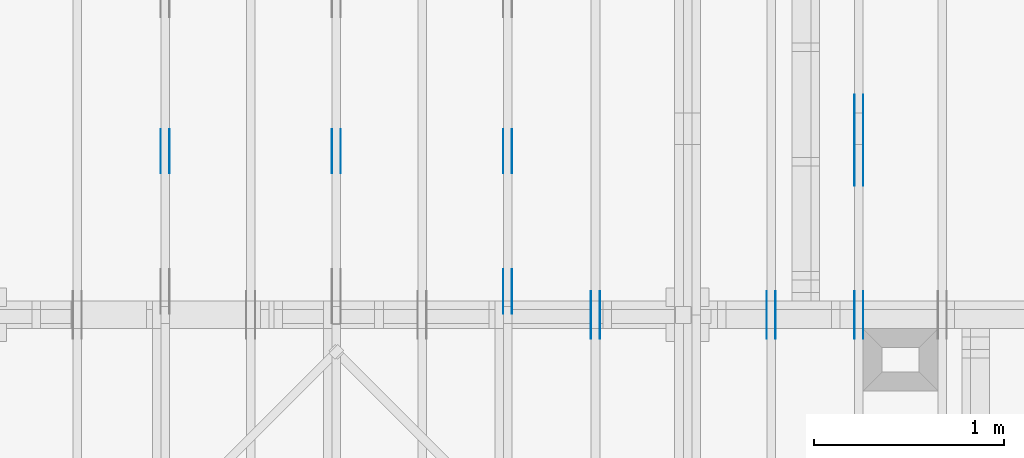
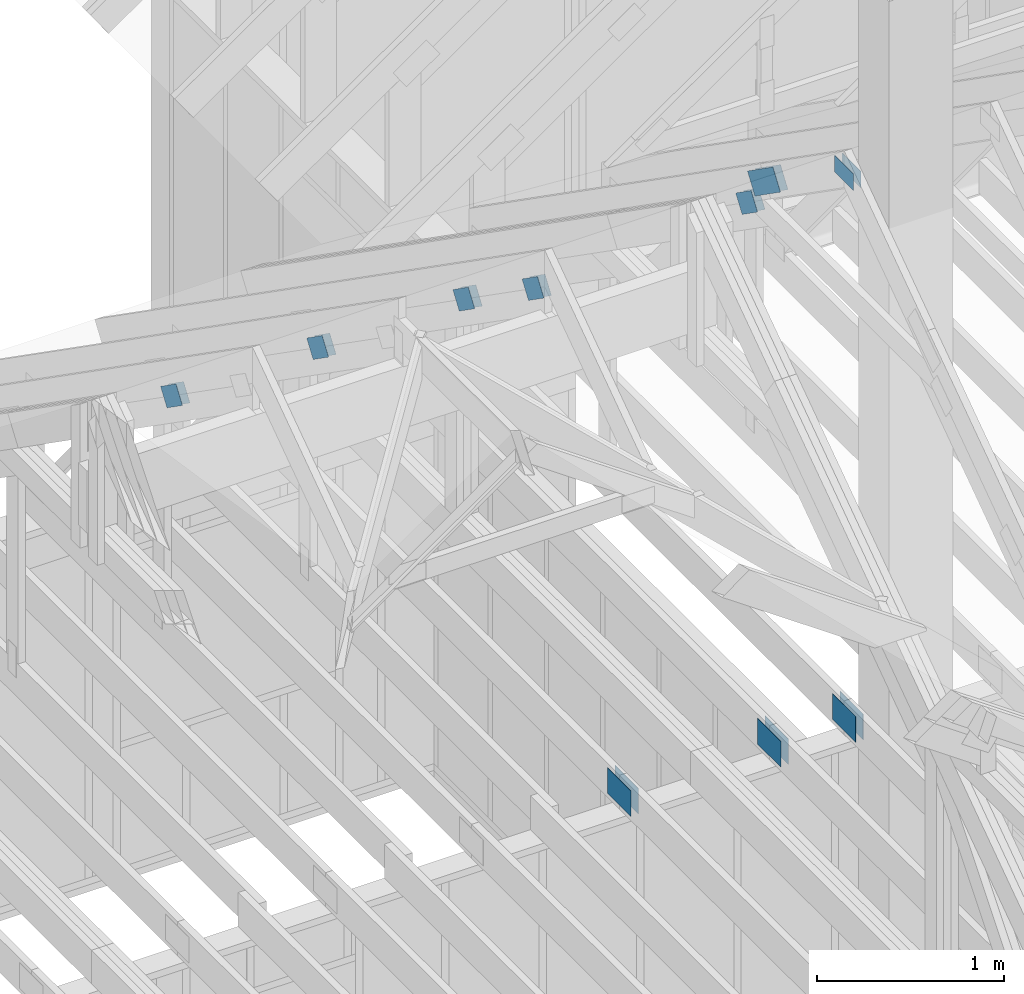
# One storey, part 49 of 70: 20 plates, 6 elements without a shape of their own.
"""IFC2X3 building model written with IfcOpenShell, lengths in millimetres."""

from ifc_helpers import new_model, si_unit, frame, origin, origin_with_axes, origin_2d, place, context, project, spatial, faceted_brep, element, aggregate, save


model = new_model("IFC2X3")

# Units and contexts
model_context = context("Model", 3, precision=1e-05, world=origin())
plan_context = context("Plan", 2, precision=1e-05, world=origin_2d())
ifc_project = project(units=[si_unit("LENGTHUNIT", "METRE", prefix="MILLI"), si_unit("AREAUNIT", "SQUARE_METRE"), si_unit("VOLUMEUNIT", "CUBIC_METRE"), si_unit("SOLIDANGLEUNIT", "STERADIAN"), si_unit("PLANEANGLEUNIT", "RADIAN"), si_unit("MASSUNIT", "GRAM"), si_unit("TIMEUNIT", "SECOND"), si_unit("THERMODYNAMICTEMPERATUREUNIT", "DEGREE_CELSIUS"), si_unit("LUMINOUSINTENSITYUNIT", "LUMEN")], contexts=[model_context, plan_context])

# Site, building, storey
site_placement = place(None, origin_with_axes())
site = spatial("IfcSite", under=ifc_project, at=site_placement, CompositionType="ELEMENT")
building_placement = place(site_placement, origin_with_axes())
building = spatial("IfcBuilding", under=site, at=building_placement, Name="Layout 1", CompositionType="ELEMENT")
storey_placement = place(building_placement, origin_with_axes())
storey = spatial("IfcBuildingStorey", under=building, at=storey_placement, Name="Storey 1", CompositionType="ELEMENT", Elevation=0.0)

# Assembly, plates
assembly_1_placement = place(storey_placement, frame((5266.250000000146, 8000.0, 1.3776821480501744e-15), z_axis=(-1.0, 1.836909530733566e-16, 6.123031769111886e-17), x_axis=(-1.836909530733566e-16, -1.0, 0.0)))
assembly_1 = element("IfcElementAssembly", 1, at=assembly_1_placement, inside=storey, Name="MB1", AssemblyPlace="FACTORY", PredefinedType="TRUSS")
plate_1_placement = place(assembly_1_placement, frame((4125.0, 193.99999999999994, 0.0), z_axis=(0.0, 0.0, 1.0), x_axis=(-1.0, 1.2246063538223773e-16, 0.0)))
plate_1 = element("IfcPlate", 2, at=plate_1_placement, context=model_context, shape_type="Brep", body=[
    faceted_brep([(250.0, 168.0, 1.3), (0.0, 168.0, 1.3), (0.0, 0.0, 1.3), (250.0, 0.0, 1.3), (0.0, 168.0, 0.0), (250.0, 168.0, 3.061515884555943e-14), (250.0, 0.0, 3.061515884555943e-14), (0.0, 0.0, 0.0), (250.0, -4.592273826833915e-14, 2.8118638534165077e-30), (250.0, -4.5843138855340694e-14, 1.3), (1.4621692037765842e-32, 7.959941299845453e-17, 1.3), (0.0, 0.0, 0.0), (250.0, 168.0, 0.0), (250.0, 168.0, 1.3), (250.0, 0.0, 1.3), (250.0, 0.0, 0.0), (0.0, 168.0, 0.0), (-4.8738973459219465e-33, 168.0, 1.3), (250.0, 167.99999999999997, 1.3), (250.0, 167.99999999999997, -1.5777218104420236e-30), (0.0, 0.0, 0.0), (7.959941299845453e-17, -9.747794691843893e-33, 1.3), (2.065298615721439e-14, 168.0, 1.3), (2.0573386744215938e-14, 168.0, -1.2597150063305954e-30)], [[[0, 1, 2, 3]], [[4, 5, 6, 7]], [[8, 9, 10, 11]], [[12, 13, 14, 15]], [[16, 17, 18, 19]], [[20, 21, 22, 23]]]),
])
plate_2_placement = place(assembly_1_placement, frame((4125.0, 193.99999999999994, -46.3), z_axis=(0.0, 0.0, 1.0), x_axis=(-1.0, 1.2246063538223773e-16, 0.0)))
plate_2 = element("IfcPlate", 3, at=plate_2_placement, context=model_context, shape_type="Brep", body=[
    faceted_brep([(250.0, 168.0, 1.2999999999999972), (0.0, 168.0, 1.2999999999999972), (0.0, 0.0, 1.2999999999999972), (250.0, 0.0, 1.2999999999999972), (0.0, 168.0, 0.0), (250.0, 168.0, 3.061515884555943e-14), (250.0, 0.0, 3.061515884555943e-14), (0.0, 0.0, 0.0), (250.0, -4.592273826833915e-14, 2.8118638534165077e-30), (250.0, -4.5843138855340694e-14, 1.2999999999999972), (1.462169203776581e-32, 7.959941299845434e-17, 1.2999999999999972), (0.0, 0.0, 0.0), (250.0, 168.0, 0.0), (250.0, 168.0, 1.2999999999999972), (250.0, 0.0, 1.2999999999999972), (250.0, 0.0, 0.0), (0.0, 168.0, 0.0), (-4.873897345921936e-33, 168.0, 1.2999999999999972), (250.0, 167.99999999999997, 1.2999999999999972), (250.0, 167.99999999999997, -1.5777218104420236e-30), (0.0, 0.0, 0.0), (7.959941299845434e-17, -9.747794691843873e-33, 1.2999999999999972), (2.065298615721439e-14, 168.0, 1.2999999999999972), (2.0573386744215938e-14, 168.0, -1.2597150063305954e-30)], [[[0, 1, 2, 3]], [[4, 5, 6, 7]], [[8, 9, 10, 11]], [[12, 13, 14, 15]], [[16, 17, 18, 19]], [[20, 21, 22, 23]]]),
])
aggregate(assembly_1, [plate_1, plate_2])

assembly_2_placement = place(storey_placement, frame((6188.750000000146, 8000.0, 1.3776821480501744e-15), z_axis=(-1.0, 1.836909530733566e-16, 6.123031769111886e-17), x_axis=(-1.836909530733566e-16, -1.0, 0.0)))
assembly_2 = element("IfcElementAssembly", 4, at=assembly_2_placement, inside=storey, Name="MB1", AssemblyPlace="FACTORY", PredefinedType="TRUSS")
plate_3_placement = place(assembly_2_placement, frame((4125.0, 193.99999999999994, 0.0), z_axis=(0.0, 0.0, 1.0), x_axis=(-1.0, 1.2246063538223773e-16, 0.0)))
plate_3 = element("IfcPlate", 5, at=plate_3_placement, context=model_context, shape_type="Brep", body=[
    faceted_brep([(250.0, 168.0, 1.3), (0.0, 168.0, 1.3), (0.0, 0.0, 1.3), (250.0, 0.0, 1.3), (0.0, 168.0, 0.0), (250.0, 168.0, 3.061515884555943e-14), (250.0, 0.0, 3.061515884555943e-14), (0.0, 0.0, 0.0), (250.0, -4.592273826833915e-14, 2.8118638534165077e-30), (250.0, -4.5843138855340694e-14, 1.3), (1.4621692037765842e-32, 7.959941299845453e-17, 1.3), (0.0, 0.0, 0.0), (250.0, 168.0, 0.0), (250.0, 168.0, 1.3), (250.0, 0.0, 1.3), (250.0, 0.0, 0.0), (0.0, 168.0, 0.0), (-4.8738973459219465e-33, 168.0, 1.3), (250.0, 167.99999999999997, 1.3), (250.0, 167.99999999999997, -1.5777218104420236e-30), (0.0, 0.0, 0.0), (7.959941299845453e-17, -9.747794691843893e-33, 1.3), (2.065298615721439e-14, 168.0, 1.3), (2.0573386744215938e-14, 168.0, -1.2597150063305954e-30)], [[[0, 1, 2, 3]], [[4, 5, 6, 7]], [[8, 9, 10, 11]], [[12, 13, 14, 15]], [[16, 17, 18, 19]], [[20, 21, 22, 23]]]),
])
plate_4_placement = place(assembly_2_placement, frame((4125.0, 193.99999999999994, -46.3), z_axis=(0.0, 0.0, 1.0), x_axis=(-1.0, 1.2246063538223773e-16, 0.0)))
plate_4 = element("IfcPlate", 6, at=plate_4_placement, context=model_context, shape_type="Brep", body=[
    faceted_brep([(250.0, 168.0, 1.2999999999999972), (0.0, 168.0, 1.2999999999999972), (0.0, 0.0, 1.2999999999999972), (250.0, 0.0, 1.2999999999999972), (0.0, 168.0, 0.0), (250.0, 168.0, 3.061515884555943e-14), (250.0, 0.0, 3.061515884555943e-14), (0.0, 0.0, 0.0), (250.0, -4.592273826833915e-14, 2.8118638534165077e-30), (250.0, -4.5843138855340694e-14, 1.2999999999999972), (1.462169203776581e-32, 7.959941299845434e-17, 1.2999999999999972), (0.0, 0.0, 0.0), (250.0, 168.0, 0.0), (250.0, 168.0, 1.2999999999999972), (250.0, 0.0, 1.2999999999999972), (250.0, 0.0, 0.0), (0.0, 168.0, 0.0), (-4.873897345921936e-33, 168.0, 1.2999999999999972), (250.0, 167.99999999999997, 1.2999999999999972), (250.0, 167.99999999999997, -1.5777218104420236e-30), (0.0, 0.0, 0.0), (7.959941299845434e-17, -9.747794691843873e-33, 1.2999999999999972), (2.065298615721439e-14, 168.0, 1.2999999999999972), (2.0573386744215938e-14, 168.0, -1.2597150063305954e-30)], [[[0, 1, 2, 3]], [[4, 5, 6, 7]], [[8, 9, 10, 11]], [[12, 13, 14, 15]], [[16, 17, 18, 19]], [[20, 21, 22, 23]]]),
])
aggregate(assembly_2, [plate_3, plate_4])

assembly_3_placement = place(storey_placement, frame((6650.000000000001, 8000.0, -9.081170196248781e-13), z_axis=(-1.0, 1.836909530733566e-16, 6.123031769111886e-17), x_axis=(-1.836909530733566e-16, -1.0, 0.0)))
assembly_3 = element("IfcElementAssembly", 7, at=assembly_3_placement, inside=storey, Name="T12", AssemblyPlace="FACTORY", PredefinedType="TRUSS")
plate_5_placement = place(assembly_3_placement, frame((3241.212504107585, 3235.9501271276167, 0.0), z_axis=(0.0, 0.0, 1.0), x_axis=(-0.8191520442889914, -0.5735764363510467, 0.0)))
plate_5 = element("IfcPlate", 8, at=plate_5_placement, context=model_context, shape_type="Brep", body=[
    faceted_brep([(330.0000000000009, 140.00000000000045, 1.5), (134.0000000000009, 140.00000000000045, 1.5), (134.0, 4.547473508864641e-13, 1.5), (330.0000000000009, 4.547473508864641e-13, 1.5), (133.9000001978775, 140.00000000000045, 1.5), (9.094947017729282e-13, 140.00000000000045, 1.5), (0.0, 4.547473508864641e-13, 1.5), (133.90000101970236, 4.547473508864641e-13, 1.5), (330.0000000000009, 140.00000000000045, 0.0), (134.0000000000009, 140.00000000000045, 0.0), (134.0, 4.547473508864641e-13, 0.0), (330.0000000000009, 4.547473508864641e-13, 0.0), (133.9000001978775, 140.00000000000045, 0.0), (9.094947017729282e-13, 140.00000000000045, 0.0), (0.0, 4.547473508864641e-13, 0.0), (133.90000101970236, 4.547473508864641e-13, 0.0), (330.0000000000009, 9.803270933743405e-13, -4.610357698653557e-29), (330.0000000000009, 9.804189388508772e-13, 1.5), (134.0, 6.682564251308046e-13, 1.5), (134.0, 6.681645796542679e-13, -4.091192948218372e-29), (133.90000101970236, 6.680053146896804e-13, 8.643095081543955e-31), (133.90000101970236, 6.680971601662171e-13, 1.5), (-1.4627915729340467e-31, 4.548391963630008e-13, 1.5), (0.0, 4.547473508864641e-13, 0.0), (133.90000101970236, 140.00000000000068, 5.032059779604519e-23), (133.90000101970236, 140.00000000000068, 1.5), (133.90000101970236, 6.821210263296962e-13, 1.5), (133.90000101970236, 6.821210263296962e-13, 0.0), (9.094947017729282e-13, 140.00000000000045, 0.0), (9.094947017729282e-13, 140.00000000000045, 1.5), (133.9000001978775, 140.00000000000068, 1.5), (133.9000001978775, 140.00000000000068, 1.5777218104420236e-30), (134.0000000000009, 140.00000000000068, 1.4199496293978212e-29), (134.0000000000009, 140.00000000000068, 1.5), (330.0000000000009, 140.00000000000102, 1.5), (330.0000000000009, 140.00000000000102, 2.208810534618833e-29), (5.56886495279458e-29, 4.547473508864641e-13, -3.409833702385498e-45), (9.184547653673398e-17, 4.547473508864641e-13, 1.5), (8.876511857361728e-13, 140.00000000000045, 1.5), (8.875593402596361e-13, 140.00000000000045, 1.3431091541284187e-30), (330.0000000000009, 140.00000000000068, 0.0), (330.0000000000009, 140.00000000000068, 1.5), (330.0000000000009, 2.2737367544323206e-13, 1.5), (330.0000000000009, 2.2737367544323206e-13, 0.0), (134.0, 0.0, 0.0), (134.0, 0.0, 1.5), (134.00000000000088, 140.00000000000045, 1.5), (134.00000000000088, 140.00000000000045, 1.5777218104420236e-30)], [[[0, 1, 2, 3]], [[4, 5, 6, 7]], [[8, 9, 10, 11]], [[12, 13, 14, 15]], [[16, 17, 18, 19]], [[20, 21, 22, 23]], [[24, 25, 26, 27]], [[28, 29, 30, 31]], [[32, 33, 34, 35]], [[36, 37, 38, 39]], [[40, 41, 42, 43]], [[44, 45, 46, 47]]]),
])
plate_6_placement = place(assembly_3_placement, frame((3241.212504107585, 3235.9501271276167, -46.5), z_axis=(0.0, 0.0, 1.0), x_axis=(-0.8191520442889914, -0.5735764363510467, 0.0)))
plate_6 = element("IfcPlate", 9, at=plate_6_placement, context=model_context, shape_type="Brep", body=[
    faceted_brep([(330.0000000000009, 140.00000000000045, 0.0), (134.0000000000009, 140.00000000000045, 0.0), (134.0, 4.547473508864641e-13, 0.0), (330.0000000000009, 4.547473508864641e-13, 0.0), (133.9000001978775, 140.00000000000045, 0.0), (9.094947017729282e-13, 140.00000000000045, 0.0), (0.0, 4.547473508864641e-13, 0.0), (133.90000101970236, 4.547473508864641e-13, 0.0), (330.0000000000009, 140.00000000000045, 1.5), (134.0000000000009, 140.00000000000045, 1.5), (134.0, 4.547473508864641e-13, 1.5), (330.0000000000009, 4.547473508864641e-13, 1.5), (133.9000001978775, 140.00000000000045, 1.5), (9.094947017729282e-13, 140.00000000000045, 1.5), (0.0, 4.547473508864641e-13, 1.5), (133.90000101970236, 4.547473508864641e-13, 1.5), (0.0, 4.547473508864641e-13, 0.0), (1.575266127070707e-31, 4.5465550540992744e-13, 1.5), (133.90000101970236, 6.843109484156988e-13, 1.5), (133.90000101970236, 6.844027938922355e-13, 1.397133527515671e-31), (134.0, 6.845743047954878e-13, 4.191670216580455e-29), (134.0, 6.844824593189511e-13, 1.5), (330.0000000000009, 1.0206472575739425e-12, 1.5), (330.0000000000009, 1.0207391030504792e-12, 4.85780171775421e-29), (133.90000101970236, 6.821210263296962e-13, 0.0), (133.90000101970236, 6.821210263296962e-13, 1.5), (133.90000019787752, 140.00000000000068, 1.5), (133.90000019787752, 140.00000000000068, 0.0), (330.0000000000009, 140.00000000000097, -1.8932661725304283e-29), (330.0000000000009, 140.00000000000097, 1.5), (134.00000000000094, 140.00000000000068, 1.5), (134.00000000000094, 140.00000000000068, -1.262177448353619e-29), (133.90000019787752, 140.00000000000068, 0.0), (133.90000019787752, 140.00000000000068, 1.5), (9.094947017729282e-13, 140.00000000000045, 1.5), (9.094947017729282e-13, 140.00000000000045, 0.0), (-2.8272774843121063e-27, 140.00000000000045, -5.568864952794597e-29), (-9.184547653950557e-17, 140.00000000000045, 1.5), (-9.184547653950557e-17, 4.547473508864641e-13, 1.5), (-2.8272774843121063e-27, 4.547473508864641e-13, -1.731150985653776e-43), (330.0000000000009, 2.2737367544323206e-13, 0.0), (330.0000000000009, 2.2737367544323206e-13, 1.5), (330.0000000000009, 140.00000000000068, 1.5), (330.0000000000009, 140.00000000000068, 0.0), (134.0, 140.00000000000045, -5.522026336547083e-29), (134.0, 140.00000000000045, 1.5), (134.0, 0.0, 1.5), (134.0, 0.0, 0.0)], [[[0, 1, 2, 3]], [[4, 5, 6, 7]], [[8, 9, 10, 11]], [[12, 13, 14, 15]], [[16, 17, 18, 19]], [[20, 21, 22, 23]], [[24, 25, 26, 27]], [[28, 29, 30, 31]], [[32, 33, 34, 35]], [[36, 37, 38, 39]], [[40, 41, 42, 43]], [[44, 45, 46, 47]]]),
])
plate_7_placement = place(assembly_3_placement, frame((3899.9999999999995, 3603.8046304341406, 0.0), z_axis=(0.0, 0.0, 1.0), x_axis=(1.0, 0.0, 0.0)))
plate_7 = element("IfcPlate", 10, at=plate_7_placement, context=model_context, shape_type="Brep", body=[
    faceted_brep([(200.00000000000045, 108.0, 1.3), (0.0, 108.0, 1.3), (0.0, 0.0, 1.3), (200.00000000000045, 0.0, 1.3), (0.0, 108.0, 0.0), (200.00000000000045, 108.0, 2.4492127076447602e-14), (200.00000000000045, 0.0, 2.4492127076447602e-14), (0.0, 0.0, 0.0), (200.00000000000045, -3.67381906146714e-14, 2.2494910827332114e-30), (200.00000000000045, -3.6658591201672947e-14, 1.3), (1.4621692037765842e-32, 7.959941299845453e-17, 1.3), (0.0, 0.0, 0.0), (200.00000000000045, 108.0, 0.0), (200.00000000000045, 108.0, 1.3), (200.00000000000045, 0.0, 1.3), (200.00000000000045, 0.0, 0.0), (0.0, 108.0, 0.0), (-4.8738973459219465e-33, 108.0, 1.3), (200.00000000000045, 107.99999999999999, 1.3), (200.00000000000045, 107.99999999999999, -7.888609052210118e-31), (0.0, 0.0, 0.0), (7.959941299845453e-17, -9.747794691843893e-33, 1.3), (1.330534803428013e-14, 108.0, 1.3), (1.3225748621281674e-14, 108.0, -8.098167897839542e-31)], [[[0, 1, 2, 3]], [[4, 5, 6, 7]], [[8, 9, 10, 11]], [[12, 13, 14, 15]], [[16, 17, 18, 19]], [[20, 21, 22, 23]]]),
])
plate_8_placement = place(assembly_3_placement, frame((3899.9999999999995, 3603.8046304341406, -46.3), z_axis=(0.0, 0.0, 1.0), x_axis=(1.0, 0.0, 0.0)))
plate_8 = element("IfcPlate", 11, at=plate_8_placement, context=model_context, shape_type="Brep", body=[
    faceted_brep([(200.00000000000045, 108.0, 1.2999999999999972), (0.0, 108.0, 1.2999999999999972), (0.0, 0.0, 1.2999999999999972), (200.00000000000045, 0.0, 1.2999999999999972), (0.0, 108.0, 0.0), (200.00000000000045, 108.0, 2.4492127076447602e-14), (200.00000000000045, 0.0, 2.4492127076447602e-14), (0.0, 0.0, 0.0), (200.00000000000045, -3.67381906146714e-14, 2.2494910827332114e-30), (200.00000000000045, -3.6658591201672947e-14, 1.2999999999999972), (1.462169203776581e-32, 7.959941299845434e-17, 1.2999999999999972), (0.0, 0.0, 0.0), (200.00000000000045, 108.0, 0.0), (200.00000000000045, 108.0, 1.2999999999999972), (200.00000000000045, 0.0, 1.2999999999999972), (200.00000000000045, 0.0, 0.0), (0.0, 108.0, 0.0), (-4.873897345921936e-33, 108.0, 1.2999999999999972), (200.00000000000045, 107.99999999999999, 1.2999999999999972), (200.00000000000045, 107.99999999999999, -7.888609052210118e-31), (0.0, 0.0, 0.0), (7.959941299845434e-17, -9.747794691843873e-33, 1.2999999999999972), (1.330534803428013e-14, 108.0, 1.2999999999999972), (1.3225748621281674e-14, 108.0, -8.098167897839542e-31)], [[[0, 1, 2, 3]], [[4, 5, 6, 7]], [[8, 9, 10, 11]], [[12, 13, 14, 15]], [[16, 17, 18, 19]], [[20, 21, 22, 23]]]),
])
plate_9_placement = place(assembly_3_placement, frame((2913.5449336777574, 2728.7886053424695, 0.0), z_axis=(0.0, 0.0, 1.0), x_axis=(0.8191520442889915, 0.5735764363510465, 0.0)))
plate_9 = element("IfcPlate", 12, at=plate_9_placement, context=model_context, shape_type="Brep", body=[
    faceted_brep([(200.0000000000009, 119.99999999999977, 1.3), (0.0, 119.99999999999977, 1.3), (4.547473508864641e-13, 0.0, 1.3), (200.0, 0.0, 1.3), (0.0, 119.99999999999977, 0.0), (200.0000000000009, 119.99999999999977, 2.4492127076447656e-14), (200.0, 0.0, 2.4492127076447545e-14), (4.547473508864641e-13, 0.0, 5.56886495279458e-29), (200.0, -3.673819061467132e-14, 2.249491082733206e-30), (200.0, -3.6658591201672864e-14, 1.3), (4.547473508864641e-13, 7.9599412998371e-17, 1.3), (4.547473508864641e-13, -8.35329742919187e-29, 5.114750553578247e-45), (200.0, 120.00000000000023, -5.522026336547083e-29), (200.0, 120.00000000000023, 1.3), (200.0, 0.0, 1.3), (200.0, 0.0, 0.0), (0.0, 119.99999999999977, 0.0), (0.0, 119.99999999999977, 1.3), (200.0000000000009, 120.00000000000026, 1.3), (200.0000000000009, 120.00000000000026, 0.0), (4.547473508864641e-13, 0.0, 0.0), (4.548269502994626e-13, 2.730461286921124e-31, 1.3), (4.3196585089271726e-14, 119.99999999999977, 1.3), (4.311698567627329e-14, 119.99999999999977, -2.6400667308416364e-30)], [[[0, 1, 2, 3]], [[4, 5, 6, 7]], [[8, 9, 10, 11]], [[12, 13, 14, 15]], [[16, 17, 18, 19]], [[20, 21, 22, 23]]]),
])
plate_10_placement = place(assembly_3_placement, frame((2913.5449336777574, 2728.7886053424695, -46.29999999999999), z_axis=(0.0, 0.0, 1.0), x_axis=(0.8191520442889915, 0.5735764363510465, 0.0)))
plate_10 = element("IfcPlate", 13, at=plate_10_placement, context=model_context, shape_type="Brep", body=[
    faceted_brep([(200.0000000000009, 119.99999999999977, 1.2999999999999972), (0.0, 119.99999999999977, 1.2999999999999972), (4.547473508864641e-13, 0.0, 1.2999999999999972), (200.0, 0.0, 1.2999999999999972), (0.0, 119.99999999999977, 0.0), (200.0000000000009, 119.99999999999977, 2.4492127076447656e-14), (200.0, 0.0, 2.4492127076447545e-14), (4.547473508864641e-13, 0.0, 5.56886495279458e-29), (200.0, -3.673819061467132e-14, 2.249491082733206e-30), (200.0, -3.6658591201672864e-14, 1.2999999999999972), (4.547473508864641e-13, 7.959941299837081e-17, 1.2999999999999972), (4.547473508864641e-13, -8.35329742919187e-29, 5.114750553578247e-45), (200.0, 120.00000000000023, -5.522026336547083e-29), (200.0, 120.00000000000023, 1.2999999999999972), (200.0, 0.0, 1.2999999999999972), (200.0, 0.0, 0.0), (0.0, 119.99999999999977, 0.0), (0.0, 119.99999999999977, 1.2999999999999972), (200.0000000000009, 120.00000000000026, 1.2999999999999972), (200.0000000000009, 120.00000000000026, 0.0), (4.547473508864641e-13, 0.0, 0.0), (4.548269502994626e-13, 2.730461286921124e-31, 1.2999999999999972), (4.3196585089271726e-14, 119.99999999999977, 1.2999999999999972), (4.311698567627329e-14, 119.99999999999977, -2.6400667308416364e-30)], [[[0, 1, 2, 3]], [[4, 5, 6, 7]], [[8, 9, 10, 11]], [[12, 13, 14, 15]], [[16, 17, 18, 19]], [[20, 21, 22, 23]]]),
])
plate_11_placement = place(assembly_3_placement, frame((4125.0, 194.0, 0.0), z_axis=(0.0, 0.0, 1.0), x_axis=(-1.0, 1.2246063538223773e-16, 0.0)))
plate_11 = element("IfcPlate", 14, at=plate_11_placement, context=model_context, shape_type="Brep", body=[
    faceted_brep([(250.0, 168.0, 1.3), (0.0, 168.0, 1.3), (0.0, 0.0, 1.3), (250.0, 0.0, 1.3), (0.0, 168.0, 0.0), (250.0, 168.0, 3.061515884555943e-14), (250.0, 0.0, 3.061515884555943e-14), (0.0, 0.0, 0.0), (250.0, -4.592273826833915e-14, 2.8118638534165077e-30), (250.0, -4.5843138855340694e-14, 1.3), (1.4621692037765842e-32, 7.959941299845453e-17, 1.3), (0.0, 0.0, 0.0), (250.0, 168.0, 0.0), (250.0, 168.0, 1.3), (250.0, 0.0, 1.3), (250.0, 0.0, 0.0), (0.0, 168.0, 0.0), (-4.8738973459219465e-33, 168.0, 1.3), (250.0, 167.99999999999997, 1.3), (250.0, 167.99999999999997, -1.5777218104420236e-30), (0.0, 0.0, 0.0), (7.959941299845453e-17, -9.747794691843893e-33, 1.3), (2.065298615721439e-14, 168.0, 1.3), (2.0573386744215938e-14, 168.0, -1.2597150063305954e-30)], [[[0, 1, 2, 3]], [[4, 5, 6, 7]], [[8, 9, 10, 11]], [[12, 13, 14, 15]], [[16, 17, 18, 19]], [[20, 21, 22, 23]]]),
])
plate_12_placement = place(assembly_3_placement, frame((4125.0, 194.0, -46.3), z_axis=(0.0, 0.0, 1.0), x_axis=(-1.0, 1.2246063538223773e-16, 0.0)))
plate_12 = element("IfcPlate", 15, at=plate_12_placement, context=model_context, shape_type="Brep", body=[
    faceted_brep([(250.0, 168.0, 1.2999999999999972), (0.0, 168.0, 1.2999999999999972), (0.0, 0.0, 1.2999999999999972), (250.0, 0.0, 1.2999999999999972), (0.0, 168.0, 0.0), (250.0, 168.0, 3.061515884555943e-14), (250.0, 0.0, 3.061515884555943e-14), (0.0, 0.0, 0.0), (250.0, -4.592273826833915e-14, 2.8118638534165077e-30), (250.0, -4.5843138855340694e-14, 1.2999999999999972), (1.462169203776581e-32, 7.959941299845434e-17, 1.2999999999999972), (0.0, 0.0, 0.0), (250.0, 168.0, 0.0), (250.0, 168.0, 1.2999999999999972), (250.0, 0.0, 1.2999999999999972), (250.0, 0.0, 0.0), (0.0, 168.0, 0.0), (-4.873897345921936e-33, 168.0, 1.2999999999999972), (250.0, 167.99999999999997, 1.2999999999999972), (250.0, 167.99999999999997, -1.5777218104420236e-30), (0.0, 0.0, 0.0), (7.959941299845434e-17, -9.747794691843873e-33, 1.2999999999999972), (2.065298615721439e-14, 168.0, 1.2999999999999972), (2.0573386744215938e-14, 168.0, -1.2597150063305954e-30)], [[[0, 1, 2, 3]], [[4, 5, 6, 7]], [[8, 9, 10, 11]], [[12, 13, 14, 15]], [[16, 17, 18, 19]], [[20, 21, 22, 23]]]),
])
aggregate(assembly_3, [plate_5, plate_6, plate_7, plate_8, plate_9, plate_10, plate_11, plate_12])

assembly_4_placement = place(storey_placement, frame((4805.0, 8000.000000000001, -4.5336966873841394e-13), z_axis=(-1.0, 1.836909530733566e-16, 6.123031769111886e-17), x_axis=(-1.836909530733566e-16, -1.0, 0.0)))
assembly_4 = element("IfcElementAssembly", 16, at=assembly_4_placement, inside=storey, Name="T1", AssemblyPlace="FACTORY", PredefinedType="TRUSS")
plate_13_placement = place(assembly_4_placement, frame((3092.3991480564946, 2854.023674486827, 0.0), z_axis=(0.0, 0.0, 1.0), x_axis=(0.8191520442889916, 0.5735764363510464, 0.0)))
plate_13 = element("IfcPlate", 17, at=plate_13_placement, context=model_context, shape_type="Brep", body=[
    faceted_brep([(200.0000000000009, 120.00000000000023, 1.3), (0.0, 120.00000000000023, 1.3), (0.0, 0.0, 1.3), (200.0000000000009, 0.0, 1.3), (0.0, 120.00000000000023, 0.0), (200.0000000000009, 120.00000000000023, 2.4492127076447656e-14), (200.0000000000009, 4.547473508864641e-13, 2.4492127076447656e-14), (0.0, 4.547473508864641e-13, 0.0), (200.0000000000009, 3.1853317726538024e-13, 8.340437124852189e-30), (200.0000000000009, 3.1861277667837867e-13, 1.3), (-1.2677526965428406e-31, 7.959941299845453e-17, 1.3), (0.0, 0.0, 0.0), (200.0000000000009, 120.00000000000068, 0.0), (200.0000000000009, 120.00000000000068, 1.3), (200.0000000000009, 4.547473508864641e-13, 1.3), (200.0000000000009, 4.547473508864641e-13, 0.0), (0.0, 120.00000000000023, 0.0), (0.0, 120.00000000000023, 1.3), (200.0000000000009, 120.00000000000071, 1.3), (200.0000000000009, 120.00000000000071, 1.5777218104420236e-30), (0.0, 0.0, 0.0), (7.959941299845453e-17, -9.747794691843893e-33, 1.3), (1.477487565886701e-14, 120.00000000000023, 1.3), (1.4695276245868555e-14, 120.00000000000023, -8.997964330932842e-31)], [[[0, 1, 2, 3]], [[4, 5, 6, 7]], [[8, 9, 10, 11]], [[12, 13, 14, 15]], [[16, 17, 18, 19]], [[20, 21, 22, 23]]]),
])
plate_14_placement = place(assembly_4_placement, frame((3092.3991480564946, 2854.023674486827, -46.3), z_axis=(0.0, 0.0, 1.0), x_axis=(0.8191520442889916, 0.5735764363510464, 0.0)))
plate_14 = element("IfcPlate", 18, at=plate_14_placement, context=model_context, shape_type="Brep", body=[
    faceted_brep([(200.0000000000009, 120.00000000000023, 1.2999999999999972), (0.0, 120.00000000000023, 1.2999999999999972), (0.0, 0.0, 1.2999999999999972), (200.0000000000009, 0.0, 1.2999999999999972), (0.0, 120.00000000000023, 0.0), (200.0000000000009, 120.00000000000023, 2.4492127076447656e-14), (200.0000000000009, 4.547473508864641e-13, 2.4492127076447656e-14), (0.0, 4.547473508864641e-13, 0.0), (200.0000000000009, 3.1853317726538024e-13, 8.340437124852189e-30), (200.0000000000009, 3.1861277667837867e-13, 1.2999999999999972), (-1.2677526965428377e-31, 7.959941299845434e-17, 1.2999999999999972), (0.0, 0.0, 0.0), (200.0000000000009, 120.00000000000068, 0.0), (200.0000000000009, 120.00000000000068, 1.2999999999999972), (200.0000000000009, 4.547473508864641e-13, 1.2999999999999972), (200.0000000000009, 4.547473508864641e-13, 0.0), (0.0, 120.00000000000023, 0.0), (0.0, 120.00000000000023, 1.2999999999999972), (200.0000000000009, 120.00000000000071, 1.2999999999999972), (200.0000000000009, 120.00000000000071, 1.5777218104420236e-30), (0.0, 0.0, 0.0), (7.959941299845434e-17, -9.747794691843873e-33, 1.2999999999999972), (1.477487565886701e-14, 120.00000000000023, 1.2999999999999972), (1.4695276245868555e-14, 120.00000000000023, -8.997964330932842e-31)], [[[0, 1, 2, 3]], [[4, 5, 6, 7]], [[8, 9, 10, 11]], [[12, 13, 14, 15]], [[16, 17, 18, 19]], [[20, 21, 22, 23]]]),
])
plate_15_placement = place(assembly_4_placement, frame((3925.435063274507, 3583.814652573151, 0.0), z_axis=(0.0, 0.0, 1.0), x_axis=(-0.8191520442890395, -0.573576436350978, 0.0)))
plate_15 = element("IfcPlate", 19, at=plate_15_placement, context=model_context, shape_type="Brep", body=[
    faceted_brep([(200.0, 120.0, 1.3), (0.0, 120.0, 1.3), (0.0, 4.547473508864641e-13, 1.3), (200.0, 4.547473508864641e-13, 1.3), (0.0, 120.0, 0.0), (200.0, 120.0, 2.4492127076447545e-14), (200.0, 0.0, 2.4492127076447545e-14), (0.0, 0.0, 0.0), (200.0, 6.273779239174271e-14, -3.841454959385866e-30), (200.0, 6.281739180474114e-14, 1.3), (1.5601865372988747e-31, 4.548269502994626e-13, 1.3), (0.0, 4.547473508864641e-13, 0.0), (200.0, 120.0, 0.0), (200.0, 120.0, 1.3), (200.0, 0.0, 1.3), (200.0, 0.0, 0.0), (0.0, 120.0, 0.0), (-4.8738973459219465e-33, 120.0, 1.3), (200.0, 119.99999999999999, 1.3), (200.0, 119.99999999999999, 0.0), (5.56886495279458e-29, 4.547473508864641e-13, -3.409833702385498e-45), (7.959941299851022e-17, 4.547473508864641e-13, 1.3), (1.477487565886698e-14, 120.0, 1.3), (1.4695276245868527e-14, 120.0, -8.997964330932825e-31)], [[[0, 1, 2, 3]], [[4, 5, 6, 7]], [[8, 9, 10, 11]], [[12, 13, 14, 15]], [[16, 17, 18, 19]], [[20, 21, 22, 23]]]),
])
plate_16_placement = place(assembly_4_placement, frame((3925.435063274507, 3583.814652573151, -46.3), z_axis=(0.0, 0.0, 1.0), x_axis=(-0.8191520442890395, -0.573576436350978, 0.0)))
plate_16 = element("IfcPlate", 20, at=plate_16_placement, context=model_context, shape_type="Brep", body=[
    faceted_brep([(200.0, 120.0, 1.2999999999999972), (0.0, 120.0, 1.2999999999999972), (0.0, 4.547473508864641e-13, 1.2999999999999972), (200.0, 4.547473508864641e-13, 1.2999999999999972), (0.0, 120.0, 0.0), (200.0, 120.0, 2.4492127076447545e-14), (200.0, 0.0, 2.4492127076447545e-14), (0.0, 0.0, 0.0), (200.0, 6.273779239174271e-14, -3.841454959385866e-30), (200.0, 6.281739180474114e-14, 1.2999999999999972), (1.5601865372988747e-31, 4.548269502994626e-13, 1.2999999999999972), (0.0, 4.547473508864641e-13, 0.0), (200.0, 120.0, 0.0), (200.0, 120.0, 1.2999999999999972), (200.0, 0.0, 1.2999999999999972), (200.0, 0.0, 0.0), (0.0, 120.0, 0.0), (-4.873897345921936e-33, 120.0, 1.2999999999999972), (200.0, 119.99999999999999, 1.2999999999999972), (200.0, 119.99999999999999, 0.0), (5.56886495279458e-29, 4.547473508864641e-13, -3.409833702385498e-45), (7.959941299851003e-17, 4.547473508864641e-13, 1.2999999999999972), (1.477487565886698e-14, 120.0, 1.2999999999999972), (1.4695276245868527e-14, 120.0, -8.997964330932825e-31)], [[[0, 1, 2, 3]], [[4, 5, 6, 7]], [[8, 9, 10, 11]], [[12, 13, 14, 15]], [[16, 17, 18, 19]], [[20, 21, 22, 23]]]),
])
aggregate(assembly_4, [plate_13, plate_14, plate_15, plate_16])

assembly_5_placement = place(storey_placement, frame((3905.0000000000005, 8000.000000000001, -4.5336966873841394e-13), z_axis=(-1.0, 1.836909530733566e-16, 6.123031769111886e-17), x_axis=(-1.836909530733566e-16, -1.0, 0.0)))
assembly_5 = element("IfcElementAssembly", 21, at=assembly_5_placement, inside=storey, Name="T1", AssemblyPlace="FACTORY", PredefinedType="TRUSS")
plate_17_placement = place(assembly_5_placement, frame((3092.3991480564946, 2854.023674486827, 0.0), z_axis=(0.0, 0.0, 1.0), x_axis=(0.8191520442889916, 0.5735764363510464, 0.0)))
plate_17 = element("IfcPlate", 22, at=plate_17_placement, context=model_context, shape_type="Brep", body=[
    faceted_brep([(200.0000000000009, 120.00000000000023, 1.3), (0.0, 120.00000000000023, 1.3), (0.0, 0.0, 1.3), (200.0000000000009, 0.0, 1.3), (0.0, 120.00000000000023, 0.0), (200.0000000000009, 120.00000000000023, 2.4492127076447656e-14), (200.0000000000009, 4.547473508864641e-13, 2.4492127076447656e-14), (0.0, 4.547473508864641e-13, 0.0), (200.0000000000009, 3.1853317726538024e-13, 8.340437124852189e-30), (200.0000000000009, 3.1861277667837867e-13, 1.3), (-1.2677526965428406e-31, 7.959941299845453e-17, 1.3), (0.0, 0.0, 0.0), (200.0000000000009, 120.00000000000068, 0.0), (200.0000000000009, 120.00000000000068, 1.3), (200.0000000000009, 4.547473508864641e-13, 1.3), (200.0000000000009, 4.547473508864641e-13, 0.0), (0.0, 120.00000000000023, 0.0), (0.0, 120.00000000000023, 1.3), (200.0000000000009, 120.00000000000071, 1.3), (200.0000000000009, 120.00000000000071, 1.5777218104420236e-30), (0.0, 0.0, 0.0), (7.959941299845453e-17, -9.747794691843893e-33, 1.3), (1.477487565886701e-14, 120.00000000000023, 1.3), (1.4695276245868555e-14, 120.00000000000023, -8.997964330932842e-31)], [[[0, 1, 2, 3]], [[4, 5, 6, 7]], [[8, 9, 10, 11]], [[12, 13, 14, 15]], [[16, 17, 18, 19]], [[20, 21, 22, 23]]]),
])
plate_18_placement = place(assembly_5_placement, frame((3092.3991480564946, 2854.023674486827, -46.3), z_axis=(0.0, 0.0, 1.0), x_axis=(0.8191520442889916, 0.5735764363510464, 0.0)))
plate_18 = element("IfcPlate", 23, at=plate_18_placement, context=model_context, shape_type="Brep", body=[
    faceted_brep([(200.0000000000009, 120.00000000000023, 1.2999999999999972), (0.0, 120.00000000000023, 1.2999999999999972), (0.0, 0.0, 1.2999999999999972), (200.0000000000009, 0.0, 1.2999999999999972), (0.0, 120.00000000000023, 0.0), (200.0000000000009, 120.00000000000023, 2.4492127076447656e-14), (200.0000000000009, 4.547473508864641e-13, 2.4492127076447656e-14), (0.0, 4.547473508864641e-13, 0.0), (200.0000000000009, 3.1853317726538024e-13, 8.340437124852189e-30), (200.0000000000009, 3.1861277667837867e-13, 1.2999999999999972), (-1.2677526965428377e-31, 7.959941299845434e-17, 1.2999999999999972), (0.0, 0.0, 0.0), (200.0000000000009, 120.00000000000068, 0.0), (200.0000000000009, 120.00000000000068, 1.2999999999999972), (200.0000000000009, 4.547473508864641e-13, 1.2999999999999972), (200.0000000000009, 4.547473508864641e-13, 0.0), (0.0, 120.00000000000023, 0.0), (0.0, 120.00000000000023, 1.2999999999999972), (200.0000000000009, 120.00000000000071, 1.2999999999999972), (200.0000000000009, 120.00000000000071, 1.5777218104420236e-30), (0.0, 0.0, 0.0), (7.959941299845434e-17, -9.747794691843873e-33, 1.2999999999999972), (1.477487565886701e-14, 120.00000000000023, 1.2999999999999972), (1.4695276245868555e-14, 120.00000000000023, -8.997964330932842e-31)], [[[0, 1, 2, 3]], [[4, 5, 6, 7]], [[8, 9, 10, 11]], [[12, 13, 14, 15]], [[16, 17, 18, 19]], [[20, 21, 22, 23]]]),
])
aggregate(assembly_5, [plate_17, plate_18])

assembly_6_placement = place(storey_placement, frame((3005.0000000000005, 8000.0, 1.3776821480501744e-15), z_axis=(-1.0, 1.836909530733566e-16, 6.123031769111886e-17), x_axis=(-1.836909530733566e-16, -1.0, 0.0)))
assembly_6 = element("IfcElementAssembly", 24, at=assembly_6_placement, inside=storey, Name="T1", AssemblyPlace="FACTORY", PredefinedType="TRUSS")
plate_19_placement = place(assembly_6_placement, frame((3092.3991480564946, 2854.023674486827, 0.0), z_axis=(0.0, 0.0, 1.0), x_axis=(0.8191520442889916, 0.5735764363510464, 0.0)))
plate_19 = element("IfcPlate", 25, at=plate_19_placement, context=model_context, shape_type="Brep", body=[
    faceted_brep([(200.0000000000009, 120.00000000000023, 1.3), (0.0, 120.00000000000023, 1.3), (0.0, 0.0, 1.3), (200.0000000000009, 0.0, 1.3), (0.0, 120.00000000000023, 0.0), (200.0000000000009, 120.00000000000023, 2.4492127076447656e-14), (200.0000000000009, 4.547473508864641e-13, 2.4492127076447656e-14), (0.0, 4.547473508864641e-13, 0.0), (200.0000000000009, 3.1853317726538024e-13, 8.340437124852189e-30), (200.0000000000009, 3.1861277667837867e-13, 1.3), (-1.2677526965428406e-31, 7.959941299845453e-17, 1.3), (0.0, 0.0, 0.0), (200.0000000000009, 120.00000000000068, 0.0), (200.0000000000009, 120.00000000000068, 1.3), (200.0000000000009, 4.547473508864641e-13, 1.3), (200.0000000000009, 4.547473508864641e-13, 0.0), (0.0, 120.00000000000023, 0.0), (0.0, 120.00000000000023, 1.3), (200.0000000000009, 120.00000000000071, 1.3), (200.0000000000009, 120.00000000000071, 1.5777218104420236e-30), (0.0, 0.0, 0.0), (7.959941299845453e-17, -9.747794691843893e-33, 1.3), (1.477487565886701e-14, 120.00000000000023, 1.3), (1.4695276245868555e-14, 120.00000000000023, -8.997964330932842e-31)], [[[0, 1, 2, 3]], [[4, 5, 6, 7]], [[8, 9, 10, 11]], [[12, 13, 14, 15]], [[16, 17, 18, 19]], [[20, 21, 22, 23]]]),
])
plate_20_placement = place(assembly_6_placement, frame((3092.3991480564946, 2854.023674486827, -46.3), z_axis=(0.0, 0.0, 1.0), x_axis=(0.8191520442889916, 0.5735764363510464, 0.0)))
plate_20 = element("IfcPlate", 26, at=plate_20_placement, context=model_context, shape_type="Brep", body=[
    faceted_brep([(200.0000000000009, 120.00000000000023, 1.2999999999999972), (0.0, 120.00000000000023, 1.2999999999999972), (0.0, 0.0, 1.2999999999999972), (200.0000000000009, 0.0, 1.2999999999999972), (0.0, 120.00000000000023, 0.0), (200.0000000000009, 120.00000000000023, 2.4492127076447656e-14), (200.0000000000009, 4.547473508864641e-13, 2.4492127076447656e-14), (0.0, 4.547473508864641e-13, 0.0), (200.0000000000009, 3.1853317726538024e-13, 8.340437124852189e-30), (200.0000000000009, 3.1861277667837867e-13, 1.2999999999999972), (-1.2677526965428377e-31, 7.959941299845434e-17, 1.2999999999999972), (0.0, 0.0, 0.0), (200.0000000000009, 120.00000000000068, 0.0), (200.0000000000009, 120.00000000000068, 1.2999999999999972), (200.0000000000009, 4.547473508864641e-13, 1.2999999999999972), (200.0000000000009, 4.547473508864641e-13, 0.0), (0.0, 120.00000000000023, 0.0), (0.0, 120.00000000000023, 1.2999999999999972), (200.0000000000009, 120.00000000000071, 1.2999999999999972), (200.0000000000009, 120.00000000000071, 1.5777218104420236e-30), (0.0, 0.0, 0.0), (7.959941299845434e-17, -9.747794691843873e-33, 1.2999999999999972), (1.477487565886701e-14, 120.00000000000023, 1.2999999999999972), (1.4695276245868555e-14, 120.00000000000023, -8.997964330932842e-31)], [[[0, 1, 2, 3]], [[4, 5, 6, 7]], [[8, 9, 10, 11]], [[12, 13, 14, 15]], [[16, 17, 18, 19]], [[20, 21, 22, 23]]]),
])
aggregate(assembly_6, [plate_19, plate_20])

save(model, "model.ifc")
